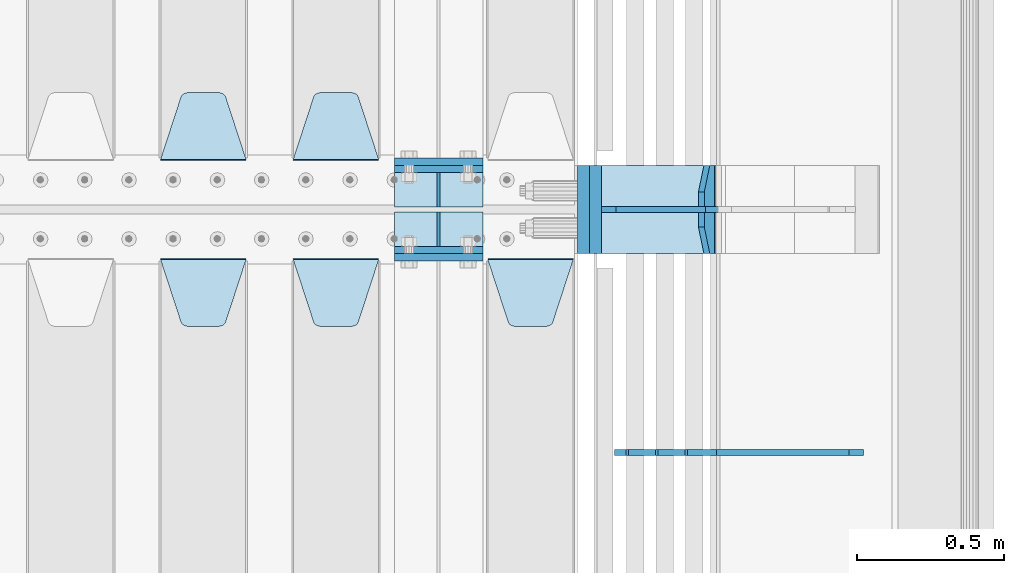
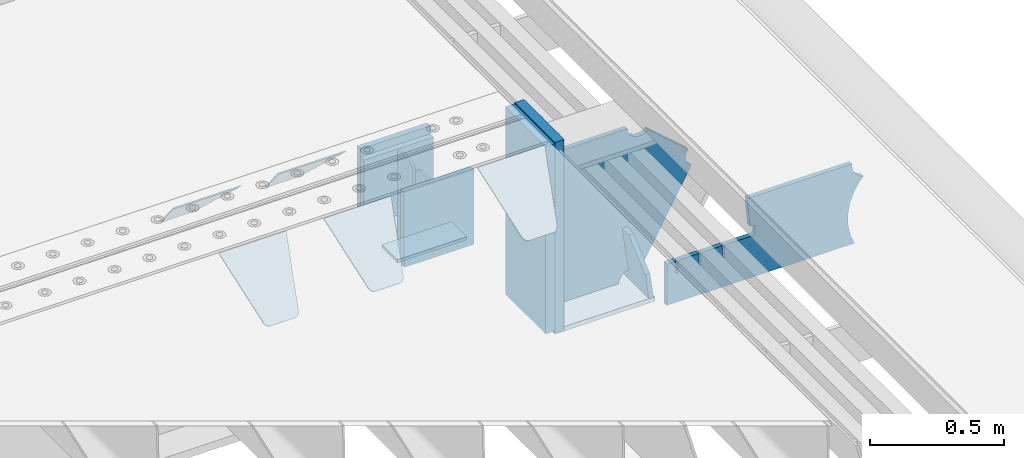
# One storey, part 247 of 270: 19 plates.
"""IFC2X3 building model written with IfcOpenShell, lengths in millimetres."""

from ifc_helpers import new_model, si_unit, frame, origin_with_axes, place, context, subcontext, project, spatial, faceted_brep, material, type_object, element, save


model = new_model("IFC2X3")

# Units and contexts
model_context = context("Model", 3, precision=1e-05, world=origin_with_axes())
body_context = subcontext(model_context, "Body", "Model", "MODEL_VIEW")
ifc_project = project(units=[si_unit("LENGTHUNIT", "METRE", prefix="MILLI"), si_unit("AREAUNIT", "SQUARE_METRE"), si_unit("VOLUMEUNIT", "CUBIC_METRE"), si_unit("MASSUNIT", "GRAM", prefix="KILO"), si_unit("TIMEUNIT", "SECOND"), si_unit("PLANEANGLEUNIT", "RADIAN"), si_unit("SOLIDANGLEUNIT", "STERADIAN"), si_unit("THERMODYNAMICTEMPERATUREUNIT", "DEGREE_CELSIUS"), si_unit("LUMINOUSINTENSITYUNIT", "LUMEN")], contexts=[model_context])

# Site, building, storey
site_placement = place(None, origin_with_axes())
site = spatial("IfcSite", under=ifc_project, at=site_placement, CompositionType="ELEMENT")
building_placement = place(site_placement, origin_with_axes())
building = spatial("IfcBuilding", under=site, at=building_placement, Name="Standard", CompositionType="ELEMENT")
storey_placement = place(building_placement, origin_with_axes())
storey = spatial("IfcBuildingStorey", under=building, at=storey_placement, Name="Undefined", CompositionType="ELEMENT", Elevation=0.0)

# Plates
ifc_material_1 = material(Name="STEEL/S355N")
plate_type_1 = type_object("IfcPlateType", PredefinedType="NOTDEFINED")
for number, where, z_axis, x_axis in (
    (1, (19768.0, -17862.5, -339.99999999999), (0.0, 0.0, 1.0), (1.0, 0.0, 0.0)),
    (2, (19768.0, -18137.5, -339.99999999999), (0.0, 0.0, 1.0), (1.0, 0.0, 0.0)),
):
    element("IfcPlate", number, at=place(storey_placement, frame(where, z_axis=z_axis, x_axis=x_axis)), inside=storey, type_object=plate_type_1, material=ifc_material_1, context=body_context, shape_type="Brep", body=[
        faceted_brep([(0.0, -12.5, 0.0), (0.0, -12.5, 305.0), (0.0, 12.5, 305.0), (0.0, 12.5, 0.0), (300.0, -12.5, 305.0), (300.0, 12.5, 305.0), (300.0, -12.5, 0.0), (300.0, 12.5, 0.0)], [[[0, 1, 2, 3]], [[1, 4, 5, 2]], [[4, 6, 7, 5]], [[6, 0, 3, 7]], [[5, 7, 3, 2]], [[6, 4, 1, 0]]]),
    ])
for number, where, z_axis, x_axis in (
    (3, (19768.0, -17837.5, -340.000000000044), (0.0, 0.0, 1.0), (1.0, 0.0, 0.0)),
    (4, (19768.0, -18162.5, -340.000000000044), (0.0, 0.0, 1.0), (1.0, 0.0, 0.0)),
):
    element("IfcPlate", number, at=place(storey_placement, frame(where, z_axis=z_axis, x_axis=x_axis)), inside=storey, type_object=plate_type_1, material=ifc_material_1, context=body_context, shape_type="Brep", body=[
        faceted_brep([(0.0, -12.5, 0.0), (9.27684595808387e-10, -12.5, 340.0), (9.27684595808387e-10, 12.5, 340.0), (0.0, 12.5, 0.0), (300.0, -12.5, 340.0), (300.0, 12.5, 340.0), (300.0, -12.5, 0.0), (300.0, 12.5, 0.0)], [[[0, 1, 2, 3]], [[1, 4, 5, 2]], [[4, 6, 7, 5]], [[6, 0, 3, 7]], [[5, 7, 3, 2]], [[6, 4, 1, 0]]]),
    ])
plate_type_2 = type_object("IfcPlateType", PredefinedType="NOTDEFINED")
for number, where, z_axis, x_axis in (
    (5, (19768.0, -17990.75, -342.99999999999), (0.0, 1.0, 0.0), (1.0, 0.0, 0.0)),
    (6, (19768.0, -18009.25, -342.99999999999), (0.0, -1.0, 0.0), (1.0, 0.0, 0.0)),
):
    element("IfcPlate", number, at=place(storey_placement, frame(where, z_axis=z_axis, x_axis=x_axis)), inside=storey, type_object=plate_type_2, material=ifc_material_1, context=body_context, shape_type="Brep", body=[
        faceted_brep([(0.0, -7.0, 0.0), (0.0, -7.0, 115.75), (0.0, 7.0, 115.75), (0.0, 7.0, 0.0), (300.0, -7.0, 115.75), (300.0, 7.0, 115.75), (300.0, -7.0, 0.0), (300.0, 7.0, 0.0)], [[[0, 1, 2, 3]], [[1, 4, 5, 2]], [[4, 6, 7, 5]], [[6, 0, 3, 7]], [[5, 7, 3, 2]], [[6, 4, 1, 0]]]),
    ])
plate_type_3 = type_object("IfcPlateType", PredefinedType="NOTDEFINED")
for number, where, z_axis, x_axis in (
    (7, (19918.0, -17990.75, -34.9999999999899), (0.0, 0.0, -1.0), (0.0, 1.0, 0.0)),
    (8, (19918.0, -18009.25, -34.9999999999899), (0.0, 0.0, -1.0), (0.0, -1.0, 0.0)),
):
    element("IfcPlate", number, at=place(storey_placement, frame(where, z_axis=z_axis, x_axis=x_axis)), inside=storey, type_object=plate_type_3, material=ifc_material_1, context=body_context, shape_type="Brep", body=[
        faceted_brep([(0.0, -5.0, 30.0), (0.0, -5.0, 301.0), (0.0, 5.0, 301.0), (0.0, 5.0, 30.0), (115.75, -5.0, 301.0), (115.75, 5.0, 301.0), (115.75, -5.0, 0.0), (115.75, 5.0, 0.0), (30.0, -5.0, 0.0), (30.0, 5.0, 0.0), (24.7905546699913, -5.0, 0.455767409633758), (24.7905546699913, 5.0, 0.455767409633758), (19.7393957002314, -5.0, 1.80922137642275), (19.7393957002314, 5.0, 1.80922137642275), (15.0, -5.0, 4.01923788646684), (15.0, 5.0, 4.01923788646684), (10.7163717094045, -5.0, 7.01866670643066), (10.7163717094045, 5.0, 7.01866670643066), (7.01866670642994, -5.0, 10.7163717094038), (7.01866670642994, 5.0, 10.7163717094038), (4.01923788646673, -5.0, 15.0), (4.01923788646673, 5.0, 15.0), (1.80922137642119, -5.0, 19.7393957002299), (1.80922137642119, 5.0, 19.7393957002299), (0.455767409632244, -5.0, 24.7905546699921), (0.455767409632244, 5.0, 24.7905546699921)], [[[0, 1, 2, 3]], [[1, 4, 5, 2]], [[4, 6, 7, 5]], [[6, 8, 9, 7]], [[8, 10, 11, 9]], [[10, 12, 13, 11]], [[12, 14, 15, 13]], [[14, 16, 17, 15]], [[16, 18, 19, 17]], [[18, 20, 21, 19]], [[20, 22, 23, 21]], [[22, 24, 25, 23]], [[24, 0, 3, 25]], [[5, 7, 9, 11, 13, 15, 17, 19, 21, 23, 25, 3, 2]], [[24, 22, 20, 18, 16, 14, 12, 10, 8, 6, 4, 1, 0]]]),
    ])
plate_type_4 = type_object("IfcPlateType", PredefinedType="NOTDEFINED")
plate_1_placement = place(storey_placement, frame((19715.0, -17831.767766953, -1.76776695296758), z_axis=(0.0, 0.707106781186547, -0.707106781186548), x_axis=(-1.0, 0.0, 0.0)))
element("IfcPlate", 9, at=plate_1_placement, inside=storey, type_object=plate_type_4, material=ifc_material_1, context=body_context, shape_type="Brep", body=[
    faceted_brep([(0.0, -2.5, 0.0), (69.345504679477, -2.5, 300.171731424831), (69.345504679477, 2.5, 300.171731424831), (0.0, 2.5, 0.0), (70.9274061199576, -2.5, 304.8974424154), (70.9274061199576, 2.5, 304.8974424154), (73.3818627772307, -2.49999999999818, 309.234538108527), (73.3818627772307, 2.50000000000182, 309.234538108527), (76.6187032999551, -2.5, 313.023683126103), (76.6187032999551, 2.5, 313.023683126103), (80.5190132704993, -2.5, 316.125672595372), (80.5190132704993, 2.50000000000182, 316.125672595372), (84.9395038596849, -2.49999999999818, 318.426546230476), (84.9395038596849, 2.5, 318.426546230476), (89.7177759439219, -2.49999999999818, 319.841774983275), (89.7177759439219, 2.50000000000182, 319.841774983275), (94.678286292652, -2.5, 320.319366455078), (94.678286292652, 2.5, 320.319366455078), (195.321713707348, -2.5, 320.319366455078), (195.321713707348, 2.5, 320.319366455078), (200.282224056078, -2.49999999999818, 319.841774983275), (200.282224056078, 2.50000000000182, 319.841774983275), (205.060496140315, -2.5, 318.426546230476), (205.060496140315, 2.5, 318.426546230476), (209.480986729501, -2.5, 316.12567259537), (209.480986729501, 2.50000000000182, 316.12567259537), (213.381296700045, -2.5, 313.023683126103), (213.381296700045, 2.5, 313.023683126103), (216.618137222769, -2.49999999999818, 309.234538108525), (216.618137222769, 2.50000000000182, 309.234538108527), (219.072593880042, -2.49999999999818, 304.897442415398), (219.072593880042, 2.50000000000182, 304.897442415397), (220.654495320523, -2.5, 300.171731424831), (220.654495320523, 2.5, 300.171731424831), (290.0, -2.49999999999818, 0.0), (290.0, 2.5, 0.0)], [[[0, 1, 2, 3]], [[1, 4, 5, 2]], [[4, 6, 7, 5]], [[6, 8, 9, 7]], [[8, 10, 11, 9]], [[10, 12, 13, 11]], [[12, 14, 15, 13]], [[14, 16, 17, 15]], [[16, 18, 19, 17]], [[18, 20, 21, 19]], [[20, 22, 23, 21]], [[22, 24, 25, 23]], [[24, 26, 27, 25]], [[26, 28, 29, 27]], [[28, 30, 31, 29]], [[30, 32, 33, 31]], [[32, 34, 35, 33]], [[34, 0, 3, 35]], [[5, 7, 9, 11, 13, 15, 17, 19, 21, 23, 25, 27, 29, 31, 33, 35, 3, 2]], [[34, 32, 30, 28, 26, 24, 22, 20, 18, 16, 14, 12, 10, 8, 6, 4, 1, 0]]]),
])
plate_2_placement = place(storey_placement, frame((19265.0, -17831.767766953, -1.76776695296758), z_axis=(0.0, 0.707106781186547, -0.707106781186548), x_axis=(-1.0, 0.0, 0.0)))
element("IfcPlate", 10, at=plate_2_placement, inside=storey, type_object=plate_type_4, material=ifc_material_1, context=body_context, shape_type="Brep", body=[
    faceted_brep([(0.0, -2.5, 0.0), (69.345504679477, -2.5, 300.171731424831), (69.345504679477, 2.5, 300.171731424831), (0.0, 2.5, 0.0), (70.9274061199576, -2.5, 304.8974424154), (70.9274061199576, 2.5, 304.8974424154), (73.3818627772307, -2.49999999999818, 309.234538108527), (73.3818627772307, 2.50000000000182, 309.234538108527), (76.6187032999551, -2.5, 313.023683126103), (76.6187032999551, 2.5, 313.023683126103), (80.5190132704993, -2.5, 316.125672595372), (80.5190132704993, 2.50000000000182, 316.125672595372), (84.9395038596849, -2.49999999999818, 318.426546230476), (84.9395038596849, 2.5, 318.426546230476), (89.7177759439219, -2.49999999999818, 319.841774983275), (89.7177759439219, 2.50000000000182, 319.841774983275), (94.678286292652, -2.5, 320.319366455078), (94.678286292652, 2.5, 320.319366455078), (195.321713707348, -2.5, 320.319366455078), (195.321713707348, 2.5, 320.319366455078), (200.282224056078, -2.49999999999818, 319.841774983275), (200.282224056078, 2.50000000000182, 319.841774983275), (205.060496140315, -2.5, 318.426546230476), (205.060496140315, 2.5, 318.426546230476), (209.480986729501, -2.5, 316.12567259537), (209.480986729501, 2.50000000000182, 316.12567259537), (213.381296700045, -2.5, 313.023683126103), (213.381296700045, 2.5, 313.023683126103), (216.618137222769, -2.49999999999818, 309.234538108525), (216.618137222769, 2.50000000000182, 309.234538108527), (219.072593880042, -2.49999999999818, 304.897442415398), (219.072593880042, 2.50000000000182, 304.897442415397), (220.654495320523, -2.5, 300.171731424831), (220.654495320523, 2.5, 300.171731424831), (290.0, -2.49999999999818, 0.0), (290.0, 2.5, 0.0)], [[[0, 1, 2, 3]], [[1, 4, 5, 2]], [[4, 6, 7, 5]], [[6, 8, 9, 7]], [[8, 10, 11, 9]], [[10, 12, 13, 11]], [[12, 14, 15, 13]], [[14, 16, 17, 15]], [[16, 18, 19, 17]], [[18, 20, 21, 19]], [[20, 22, 23, 21]], [[22, 24, 25, 23]], [[24, 26, 27, 25]], [[26, 28, 29, 27]], [[28, 30, 31, 29]], [[30, 32, 33, 31]], [[32, 34, 35, 33]], [[34, 0, 3, 35]], [[5, 7, 9, 11, 13, 15, 17, 19, 21, 23, 25, 27, 29, 31, 33, 35, 3, 2]], [[34, 32, 30, 28, 26, 24, 22, 20, 18, 16, 14, 12, 10, 8, 6, 4, 1, 0]]]),
])
plate_3_placement = place(storey_placement, frame((20085.0, -18168.232233044, -1.76776695296576), z_axis=(0.0, -0.707106781186548, -0.707106781186547), x_axis=(1.0, 0.0, 0.0)))
element("IfcPlate", 11, at=plate_3_placement, inside=storey, type_object=plate_type_4, material=ifc_material_1, context=body_context, shape_type="Brep", body=[
    faceted_brep([(0.0, -2.5, 0.0), (69.345504679477, -2.5, 300.171731424831), (69.345504679477, 2.5, 300.171731424831), (0.0, 2.5, 0.0), (70.9274061199576, -2.5, 304.8974424154), (70.9274061199576, 2.5, 304.8974424154), (73.3818627772307, -2.49999999999818, 309.234538108527), (73.3818627772307, 2.50000000000182, 309.234538108527), (76.6187032999551, -2.5, 313.023683126103), (76.6187032999551, 2.5, 313.023683126103), (80.5190132704993, -2.5, 316.125672595372), (80.5190132704993, 2.50000000000182, 316.125672595372), (84.9395038596849, -2.49999999999818, 318.426546230476), (84.9395038596849, 2.5, 318.426546230476), (89.7177759439219, -2.49999999999818, 319.841774983275), (89.7177759439219, 2.50000000000182, 319.841774983275), (94.678286292652, -2.5, 320.319366455078), (94.678286292652, 2.5, 320.319366455078), (195.321713707348, -2.5, 320.319366455078), (195.321713707348, 2.5, 320.319366455078), (200.282224056078, -2.49999999999818, 319.841774983275), (200.282224056078, 2.50000000000182, 319.841774983275), (205.060496140315, -2.5, 318.426546230476), (205.060496140315, 2.5, 318.426546230476), (209.480986729501, -2.5, 316.12567259537), (209.480986729501, 2.50000000000182, 316.12567259537), (213.381296700045, -2.5, 313.023683126103), (213.381296700045, 2.5, 313.023683126103), (216.618137222769, -2.49999999999818, 309.234538108525), (216.618137222769, 2.50000000000182, 309.234538108527), (219.072593880042, -2.49999999999818, 304.897442415398), (219.072593880042, 2.50000000000182, 304.897442415397), (220.654495320523, -2.5, 300.171731424831), (220.654495320523, 2.5, 300.171731424831), (290.0, -2.49999999999818, 0.0), (290.0, 2.5, 0.0)], [[[0, 1, 2, 3]], [[1, 4, 5, 2]], [[4, 6, 7, 5]], [[6, 8, 9, 7]], [[8, 10, 11, 9]], [[10, 12, 13, 11]], [[12, 14, 15, 13]], [[14, 16, 17, 15]], [[16, 18, 19, 17]], [[18, 20, 21, 19]], [[20, 22, 23, 21]], [[22, 24, 25, 23]], [[24, 26, 27, 25]], [[26, 28, 29, 27]], [[28, 30, 31, 29]], [[30, 32, 33, 31]], [[32, 34, 35, 33]], [[34, 0, 3, 35]], [[5, 7, 9, 11, 13, 15, 17, 19, 21, 23, 25, 27, 29, 31, 33, 35, 3, 2]], [[34, 32, 30, 28, 26, 24, 22, 20, 18, 16, 14, 12, 10, 8, 6, 4, 1, 0]]]),
])
plate_4_placement = place(storey_placement, frame((19425.0, -18168.232233044, -1.76776695296576), z_axis=(0.0, -0.707106781186548, -0.707106781186547), x_axis=(1.0, 0.0, 0.0)))
element("IfcPlate", 12, at=plate_4_placement, inside=storey, type_object=plate_type_4, material=ifc_material_1, context=body_context, shape_type="Brep", body=[
    faceted_brep([(0.0, -2.5, 0.0), (69.345504679477, -2.5, 300.171731424831), (69.345504679477, 2.5, 300.171731424831), (0.0, 2.5, 0.0), (70.9274061199576, -2.5, 304.8974424154), (70.9274061199576, 2.5, 304.8974424154), (73.3818627772307, -2.49999999999818, 309.234538108527), (73.3818627772307, 2.50000000000182, 309.234538108527), (76.6187032999551, -2.5, 313.023683126103), (76.6187032999551, 2.5, 313.023683126103), (80.5190132704993, -2.5, 316.125672595372), (80.5190132704993, 2.50000000000182, 316.125672595372), (84.9395038596849, -2.49999999999818, 318.426546230476), (84.9395038596849, 2.5, 318.426546230476), (89.7177759439219, -2.49999999999818, 319.841774983275), (89.7177759439219, 2.50000000000182, 319.841774983275), (94.678286292652, -2.5, 320.319366455078), (94.678286292652, 2.5, 320.319366455078), (195.321713707348, -2.5, 320.319366455078), (195.321713707348, 2.5, 320.319366455078), (200.282224056078, -2.49999999999818, 319.841774983275), (200.282224056078, 2.50000000000182, 319.841774983275), (205.060496140315, -2.5, 318.426546230476), (205.060496140315, 2.5, 318.426546230476), (209.480986729501, -2.5, 316.12567259537), (209.480986729501, 2.50000000000182, 316.12567259537), (213.381296700045, -2.5, 313.023683126103), (213.381296700045, 2.5, 313.023683126103), (216.618137222769, -2.49999999999818, 309.234538108525), (216.618137222769, 2.50000000000182, 309.234538108527), (219.072593880042, -2.49999999999818, 304.897442415398), (219.072593880042, 2.50000000000182, 304.897442415397), (220.654495320523, -2.5, 300.171731424831), (220.654495320523, 2.5, 300.171731424831), (290.0, -2.49999999999818, 0.0), (290.0, 2.5, 0.0)], [[[0, 1, 2, 3]], [[1, 4, 5, 2]], [[4, 6, 7, 5]], [[6, 8, 9, 7]], [[8, 10, 11, 9]], [[10, 12, 13, 11]], [[12, 14, 15, 13]], [[14, 16, 17, 15]], [[16, 18, 19, 17]], [[18, 20, 21, 19]], [[20, 22, 23, 21]], [[22, 24, 25, 23]], [[24, 26, 27, 25]], [[26, 28, 29, 27]], [[28, 30, 31, 29]], [[30, 32, 33, 31]], [[32, 34, 35, 33]], [[34, 0, 3, 35]], [[5, 7, 9, 11, 13, 15, 17, 19, 21, 23, 25, 27, 29, 31, 33, 35, 3, 2]], [[34, 32, 30, 28, 26, 24, 22, 20, 18, 16, 14, 12, 10, 8, 6, 4, 1, 0]]]),
])
plate_5_placement = place(storey_placement, frame((18975.0, -18168.232233044, -1.76776695296576), z_axis=(0.0, -0.707106781186548, -0.707106781186547), x_axis=(1.0, 0.0, 0.0)))
element("IfcPlate", 13, at=plate_5_placement, inside=storey, type_object=plate_type_4, material=ifc_material_1, context=body_context, shape_type="Brep", body=[
    faceted_brep([(0.0, -2.5, 0.0), (69.345504679477, -2.5, 300.171731424831), (69.345504679477, 2.5, 300.171731424831), (0.0, 2.5, 0.0), (70.9274061199576, -2.5, 304.8974424154), (70.9274061199576, 2.5, 304.8974424154), (73.3818627772307, -2.49999999999818, 309.234538108527), (73.3818627772307, 2.50000000000182, 309.234538108527), (76.6187032999551, -2.5, 313.023683126103), (76.6187032999551, 2.5, 313.023683126103), (80.5190132704993, -2.5, 316.125672595372), (80.5190132704993, 2.50000000000182, 316.125672595372), (84.9395038596849, -2.49999999999818, 318.426546230476), (84.9395038596849, 2.5, 318.426546230476), (89.7177759439219, -2.49999999999818, 319.841774983275), (89.7177759439219, 2.50000000000182, 319.841774983275), (94.678286292652, -2.5, 320.319366455078), (94.678286292652, 2.5, 320.319366455078), (195.321713707348, -2.5, 320.319366455078), (195.321713707348, 2.5, 320.319366455078), (200.282224056078, -2.49999999999818, 319.841774983275), (200.282224056078, 2.50000000000182, 319.841774983275), (205.060496140315, -2.5, 318.426546230476), (205.060496140315, 2.5, 318.426546230476), (209.480986729501, -2.5, 316.12567259537), (209.480986729501, 2.50000000000182, 316.12567259537), (213.381296700045, -2.5, 313.023683126103), (213.381296700045, 2.5, 313.023683126103), (216.618137222769, -2.49999999999818, 309.234538108525), (216.618137222769, 2.50000000000182, 309.234538108527), (219.072593880042, -2.49999999999818, 304.897442415398), (219.072593880042, 2.50000000000182, 304.897442415397), (220.654495320523, -2.5, 300.171731424831), (220.654495320523, 2.5, 300.171731424831), (290.0, -2.49999999999818, 0.0), (290.0, 2.5, 0.0)], [[[0, 1, 2, 3]], [[1, 4, 5, 2]], [[4, 6, 7, 5]], [[6, 8, 9, 7]], [[8, 10, 11, 9]], [[10, 12, 13, 11]], [[12, 14, 15, 13]], [[14, 16, 17, 15]], [[16, 18, 19, 17]], [[18, 20, 21, 19]], [[20, 22, 23, 21]], [[22, 24, 25, 23]], [[24, 26, 27, 25]], [[26, 28, 29, 27]], [[28, 30, 31, 29]], [[30, 32, 33, 31]], [[32, 34, 35, 33]], [[34, 0, 3, 35]], [[5, 7, 9, 11, 13, 15, 17, 19, 21, 23, 25, 27, 29, 31, 33, 35, 3, 2]], [[34, 32, 30, 28, 26, 24, 22, 20, 18, 16, 14, 12, 10, 8, 6, 4, 1, 0]]]),
])
plate_type_5 = type_object("IfcPlateType", PredefinedType="NOTDEFINED")
plate_6_placement = place(storey_placement, frame((20844.0775331946, -17849.9999999983, -871.412303810021), z_axis=(0.0, -1.0, 0.0), x_axis=(-0.137902988002447, 0.0, 0.990445741017648)))
element("IfcPlate", 14, at=plate_6_placement, inside=storey, type_object=plate_type_5, material=ifc_material_1, context=body_context, shape_type="Brep", body=[
    faceted_brep([(0.0, -10.0, 0.0), (-1.98724592337385e-10, -10.0000000000036, 300.0), (-1.98724592337385e-10, 10.0, 300.0), (0.0, 10.0, 0.0), (115.0, -10.0000000000036, 300.0), (115.0, 9.99999999999272, 300.0), (250.0, -10.0, 210.0), (250.0, 9.99999999999636, 210.0), (250.0, -10.0, 90.0), (250.0, 9.99999999999636, 90.0), (115.0, -10.0000000000036, -1.09139364212751e-10), (115.0, 9.99999999999272, -1.09139364212751e-10)], [[[0, 1, 2, 3]], [[1, 4, 5, 2]], [[4, 6, 7, 5]], [[6, 8, 9, 7]], [[8, 10, 11, 9]], [[10, 0, 3, 11]], [[5, 7, 9, 11, 3, 2]], [[10, 8, 6, 4, 1, 0]]]),
])
plate_type_6 = type_object("IfcPlateType", PredefinedType="NOTDEFINED")
plate_7_placement = place(storey_placement, frame((20872.9988298913, -17999.9999999999, -179.999999999866), z_axis=(0.0, 0.0, -1.0), x_axis=(-1.0, 0.0, 0.0)))
element("IfcPlate", 15, at=plate_7_placement, inside=storey, type_object=plate_type_6, material=ifc_material_1, context=body_context, shape_type="Brep", body=[
    faceted_brep([(46.0258547361445, 10.0, 641.078828352486), (73.3015011074785, 10.0000000000073, 445.179898435767), (73.3015011074785, -9.99999999998909, 445.179898435767), (46.0258547361445, -10.0, 641.078828352486), (53.4925862871278, 10.0000000000073, 442.421838675718), (53.4925862871278, -9.99999999998909, 442.421838675718), (25.7820501123933, 10.0, 641.444230671287), (25.7820501123933, -10.0, 641.444230671287), (54.6652503111618, 10.0, 642.447174185377), (54.6652503111618, -10.0, 642.447174185377), (68.6036632070354, -10.0, 649.549150281387), (68.6036632070354, 10.0, 649.549150281387), (79.6652503111618, -10.0, 660.610737385511), (79.6652503111618, 10.0, 660.610737385511), (86.7672264071698, -10.0, 674.549150281387), (86.7672264071698, 10.0, 674.549150281387), (89.2144005924129, -10.0, 690.0), (89.2144005924129, 10.0, 690.0), (353.0, -10.0, 690.0), (353.0, 10.0, 690.0), (355.447174185243, -10.0, 674.549150281253), (355.447174185243, 10.0, 674.549150281253), (362.549150281251, -10.0, 660.610737385376), (362.549150281251, 10.0, 660.610737385376), (373.610737385377, -10.0, 649.549150281253), (373.610737385377, 10.0, 649.549150281253), (387.549150281251, -10.0, 642.447174185242), (387.549150281251, 10.0, 642.447174185242), (403.0, -10.0, 640.0), (403.0, 10.0, 640.0), (403.0, -10.0, 50.0), (403.0, 10.0, 50.0), (387.549150281251, -10.0, 47.5528258147577), (387.549150281251, 10.0, 47.5528258147577), (373.610737385377, -10.0, 40.4508497187474), (373.610737385377, 10.0, 40.4508497187474), (362.549150281251, -10.0, 29.3892626146236), (362.549150281251, 10.0, 29.3892626146236), (355.447174185243, -10.0, 15.4508497187474), (355.447174185243, 10.0, 15.4508497187474), (353.0, -10.0, 0.0), (353.0, 10.0, 0.0), (50.0, -10.0, 0.0), (50.0, 10.0, 0.0), (47.0349915316328, -10.0, 16.9620037619133), (47.0349915316328, 10.0, 16.9620037619133), (38.4916171352343, -10.0, 31.9123081320451), (38.4916171352343, 10.0, 31.9123081320451), (25.3831239081519, -10.0, 43.0778019479116), (25.3831239081519, 10.0, 43.0778019479116), (9.26418358741648, -10.0, 49.1342538608113), (9.26418358741648, 10.0, 49.1342538608113), (-7.95349204488593, -10.0, 49.363366622344), (-7.95349204488593, 10.0, 49.363366622344), (-24.2278808265401, -10.0, 43.7379673813837), (-24.2278808265401, 10.0, 43.7379673813837), (-37.6288347353438, -10.0, 32.9252303934259), (-37.6288347353438, 10.0, 32.9252303934259), (-210.371165264656, -10.0, 184.074769606574), (-210.371165264656, 10.0, 184.074769606574), (-202.382363280569, -10.0, 196.529747922069), (-202.382363280569, 10.0, 196.529747922069), (-198.388707244045, -10.0, 210.777489969227), (-198.388707244045, 10.0, 210.777489969227), (-198.739957464426, -10.0, 225.570193077959), (-198.739957464426, 10.0, 225.570193077959), (-203.40535180681, -10.0, 239.612327446012), (-203.40535180681, 10.0, 239.612327446012), (-211.976299808361, -10.0, 251.674097313455), (-211.976299808361, 10.0, 251.674097313455), (-223.702166612962, -10.0, 260.699145216992), (-223.702166612962, 10.0, 260.699145216992), (-9.29783338703783, -10.0, 646.300854783008), (-9.29783338703783, 10.0, 646.300854783008), (6.98069453597782, -10.0, 640.647282345602), (6.98069453597782, 10.0, 640.647282345602), (24.2117663163663, -10.0, 640.855891896051), (24.2117663163663, 10.0, 640.855891896051)], [[[0, 1, 2, 3]], [[4, 5, 2, 1]], [[6, 7, 5, 4]], [[8, 9, 10, 11]], [[11, 10, 12, 13]], [[13, 12, 14, 15]], [[15, 14, 16, 17]], [[18, 19, 17, 16]], [[18, 20, 21, 19]], [[20, 22, 23, 21]], [[22, 24, 25, 23]], [[24, 26, 27, 25]], [[26, 28, 29, 27]], [[28, 30, 31, 29]], [[30, 32, 33, 31]], [[32, 34, 35, 33]], [[34, 36, 37, 35]], [[36, 38, 39, 37]], [[38, 40, 41, 39]], [[40, 42, 43, 41]], [[42, 44, 45, 43]], [[44, 46, 47, 45]], [[46, 48, 49, 47]], [[48, 50, 51, 49]], [[50, 52, 53, 51]], [[52, 54, 55, 53]], [[54, 56, 57, 55]], [[56, 58, 59, 57]], [[58, 60, 61, 59]], [[60, 62, 63, 61]], [[62, 64, 65, 63]], [[64, 66, 67, 65]], [[66, 68, 69, 67]], [[68, 70, 71, 69]], [[70, 72, 73, 71]], [[72, 74, 75, 73]], [[74, 76, 77, 75]], [[1, 0, 8, 11, 13, 15, 17, 19, 21, 23, 25, 27, 29, 31, 33, 35, 37, 39, 41, 43, 45, 47, 49, 51, 53, 55, 57, 59, 61, 63, 65, 67, 69, 71, 73, 75, 77, 6, 4]], [[9, 8, 0, 3]], [[76, 74, 72, 70, 68, 66, 64, 62, 60, 58, 56, 54, 52, 50, 48, 46, 44, 42, 40, 38, 36, 34, 32, 30, 28, 26, 24, 22, 20, 18, 16, 14, 12, 10, 9, 3, 2, 5, 7]], [[77, 76, 7, 6]]]),
])
plate_type_7 = type_object("IfcPlateType", PredefinedType="NOTDEFINED")
plate_8_placement = place(storey_placement, frame((20469.9988298913, -17849.9999999999, -879.999999999866), z_axis=(0.0, -1.0, 0.0), x_axis=(1.0, 0.0, 0.0)))
element("IfcPlate", 16, at=plate_8_placement, inside=storey, type_object=plate_type_7, material=ifc_material_1, context=body_context, shape_type="Brep", body=[
    faceted_brep([(0.0, -10.0, 0.0), (-1.98724592337385e-10, -10.0000000000036, 300.0), (-1.98724592337385e-10, 10.0, 300.0), (0.0, 10.0, 0.0), (389.0, -10.0, 300.0), (389.0, 10.0, 300.0), (389.0, -10.0, 0.0), (389.0, 10.0, 0.0)], [[[0, 1, 2, 3]], [[1, 4, 5, 2]], [[4, 6, 7, 5]], [[6, 0, 3, 7]], [[5, 7, 3, 2]], [[6, 4, 1, 0]]]),
])
ifc_material_2 = material()
plate_type_8 = type_object("IfcPlateType", PredefinedType="NOTDEFINED")
plate_9_placement = place(storey_placement, frame((20410.0, -17850.0, -875.0), z_axis=(0.0, 0.0, 1.0), x_axis=(0.0, -1.0, 0.0)))
element("IfcPlate", 17, at=plate_9_placement, inside=storey, type_object=plate_type_8, material=ifc_material_2, context=body_context, shape_type="Brep", body=[
    faceted_brep([(0.0, -20.0, 0.0), (0.0, -20.0, 850.0), (0.0, 20.0, 850.0), (0.0, 20.0, 0.0), (300.0, -20.0, 850.0), (300.0, 20.0, 850.0), (300.0, -20.0, -1.81898940354586e-12), (300.0, 20.0, -1.81898940354586e-12)], [[[0, 1, 2, 3]], [[1, 4, 5, 2]], [[4, 6, 7, 5]], [[6, 0, 3, 7]], [[5, 7, 3, 2]], [[6, 4, 1, 0]]]),
])
plate_10_placement = place(storey_placement, frame((20449.9988298906, -17850.0, -889.999999999995), z_axis=(0.0, 0.0, 1.0), x_axis=(0.0, -1.0, 0.0)))
element("IfcPlate", 18, at=plate_10_placement, inside=storey, type_object=plate_type_8, material=ifc_material_2, context=body_context, shape_type="Brep", body=[
    faceted_brep([(0.0, -20.0, 0.0), (0.0, -20.0, 870.0), (0.0, 20.0, 870.0), (0.0, 20.0, 0.0), (300.0, -20.0, 870.0), (300.0, 20.0, 870.0), (300.0, -20.0, -1.81898940354586e-12), (300.0, 20.0, -1.81898940354586e-12)], [[[0, 1, 2, 3]], [[1, 4, 5, 2]], [[4, 6, 7, 5]], [[6, 0, 3, 7]], [[5, 7, 3, 2]], [[6, 4, 1, 0]]]),
])
plate_type_9 = type_object("IfcPlateType", PredefinedType="NOTDEFINED")
plate_11_placement = place(storey_placement, frame((21355.9182339676, -18825.0007171631, -374.002067436516), z_axis=(0.0, 0.0, 1.0), x_axis=(-1.0, 0.0, 0.0)))
element("IfcPlate", 19, at=plate_11_placement, inside=storey, type_object=plate_type_9, material=ifc_material_1, context=body_context, shape_type="Brep", body=[
    faceted_brep([(801.919404066546, -10.0, 188.0), (801.919404066546, 10.0, 188.0), (801.919404066546, 10.0, 132.002067436952), (801.919404066546, -10.0, 132.002067436952), (793.919404066546, 10.0, 132.002067436952), (793.919404066546, -10.0, 132.002067436952), (793.919404066546, 10.0, 180.002067436952), (793.919404066546, -10.0, 180.002067436952), (793.527856196906, 10.0, 182.474203391951), (793.527856196906, -10.0, 182.474203391951), (792.391540021545, 10.0, 184.704349455291), (792.391540021545, -10.0, 184.704349455291), (790.621686084887, 10.0, 186.474203391951), (790.621686084887, -10.0, 186.474203391951), (788.391540021545, 10.0, 187.610519567313), (788.391540021545, -10.0, 187.610519567313), (785.919404066546, -10.0, 188.002067436952), (785.919404066546, 10.0, 188.0), (841.0, -10.0, 188.0), (841.0, -10.0, 0.0), (841.0, 10.0, 0.0), (841.0, 10.0, 188.0), (33.3619566735979, -10.0, 0.0), (33.3619566735979, 10.0, 0.0), (36.2350612208174, -10.0, 4.68848050267013), (36.2350612208174, 10.0, 4.68848050267013), (51.4877592159428, -10.0, 41.5117508652784), (51.4877592159428, 10.0, 41.5117508652784), (60.792242588137, -10.0, 80.2677133162964), (60.792242588137, 10.0, 80.2677133162964), (63.9194040769726, -10.0, 120.002067436515), (63.9194040769726, 10.0, 120.002067436515), (60.792242588137, -10.0, 159.736421556734), (60.792242588137, 10.0, 159.736421556734), (51.4877592159428, -10.0, 198.492384007752), (51.4877592159428, 10.0, 198.492384007752), (36.2350612208174, -10.0, 235.31565437036), (36.2350612208174, 10.0, 235.31565437036), (15.4097206482074, -10.0, 269.299521518803), (15.4097206482074, 10.0, 269.299521518803), (-3.35474438098754, -10.0, 291.269887256574), (-3.35474438098754, 10.0, 291.269887256574), (-2.36881039375294, -10.0, 291.426043859339), (-2.36881039375294, 10.0, 291.426043859339), (17.1449676604716, -10.0, 301.368810393754), (17.1449676604716, 10.0, 301.368810393754), (32.6311896062471, -10.0, 316.855032339527), (32.6311896062471, 10.0, 316.855032339527), (42.573956140659, -10.0, 336.368810393754), (42.573956140659, 10.0, 336.368810393754), (46.0, -10.0, 358.0), (46.0, 10.0, 358.0), (45.0495205499174, -10.0, 364.001091067617), (45.0495205499174, 10.0, 364.001091067617), (495.040008544922, -10.0, 364.010009765625), (495.040008544922, 10.0, 364.010009765625), (483.600036621094, -10.0, 233.759994506836), (483.600036621094, 10.0, 233.759994506836), (472.0, -10.0, 233.759994506836), (472.0, 10.0, 233.759994506836), (468.909830056251, -10.0, 233.270559669787), (468.909830056251, 10.0, 233.270559669787), (466.122147477075, -10.0, 231.850164450585), (466.122147477075, 10.0, 231.850164450585), (463.909830056251, -10.0, 229.637847029761), (463.909830056251, 10.0, 229.637847029761), (462.489434837047, -10.0, 226.850164450585), (462.489434837047, 10.0, 226.850164450585), (462.0, -10.0, 223.759994506836), (462.0, 10.0, 223.759994506836), (462.0, -10.0, 198.0), (462.0, 10.0, 198.0), (462.489434837047, -10.0, 194.909830056251), (462.489434837047, 10.0, 194.909830056251), (463.909830056251, -10.0, 192.122147477075), (463.909830056251, 10.0, 192.122147477075), (466.122147477075, -10.0, 189.909830056251), (466.122147477075, 10.0, 189.909830056251), (468.909830056251, -10.0, 188.489434837048), (468.909830056251, 10.0, 188.489434837048), (472.0, -10.0, 188.0), (472.0, 10.0, 188.0), (585.919404066546, -10.0, 188.002067436952), (585.919404066546, 10.0, 188.0), (588.391540021545, -10.0, 187.610519567313), (588.391540021545, 10.0, 187.610519567313), (590.621686084887, -10.0, 186.474203391951), (590.621686084887, 10.0, 186.474203391951), (592.391540021545, -10.0, 184.704349455291), (592.391540021545, 10.0, 184.704349455291), (593.527856196906, -10.0, 182.474203391951), (593.527856196906, 10.0, 182.474203391951), (593.919404066546, -10.0, 180.002067436952), (593.919404066546, 10.0, 180.002067436952), (593.919404066546, -10.0000000000036, 132.002067436952), (593.919404066546, 10.0, 132.002067436952), (601.919404066546, -10.0000000000036, 132.002067436952), (601.919404066546, 10.0, 132.002067436952), (601.919404066546, -10.0, 188.0), (601.919404066546, 10.0, 188.0), (685.919404066546, -10.0, 188.002067436952), (685.919404066546, 10.0, 188.0), (688.391540021545, -10.0, 187.610519567313), (688.391540021545, 10.0, 187.610519567313), (690.621686084887, -10.0, 186.474203391951), (690.621686084887, 10.0, 186.474203391951), (692.391540021545, -10.0, 184.704349455291), (692.391540021545, 10.0, 184.704349455291), (693.527856196906, -10.0, 182.474203391951), (693.527856196906, 10.0, 182.474203391951), (693.919404066546, -10.0, 180.002067436952), (693.919404066546, 10.0, 180.002067436952), (693.919404066546, -10.0, 132.002067436952), (693.919404066546, 10.0, 132.002067436952), (701.919404066546, -10.0, 132.002067436952), (701.919404066546, 10.0, 132.002067436952), (701.919404066546, -10.0, 188.0), (701.919404066546, 10.0, 188.0)], [[[0, 1, 2, 3]], [[3, 2, 4, 5]], [[5, 4, 6, 7]], [[7, 6, 8, 9]], [[9, 8, 10, 11]], [[11, 10, 12, 13]], [[13, 12, 14, 15]], [[16, 15, 14, 17]], [[18, 19, 20, 21]], [[20, 19, 22, 23]], [[22, 24, 25, 23]], [[26, 27, 25, 24]], [[28, 29, 27, 26]], [[30, 31, 29, 28]], [[32, 33, 31, 30]], [[34, 35, 33, 32]], [[36, 37, 35, 34]], [[38, 39, 37, 36]], [[39, 38, 40, 41]], [[40, 42, 43, 41]], [[44, 45, 43, 42]], [[46, 47, 45, 44]], [[48, 49, 47, 46]], [[50, 51, 49, 48]], [[52, 53, 51, 50]], [[54, 55, 53, 52]], [[54, 56, 57, 55]], [[56, 58, 59, 57]], [[58, 60, 61, 59]], [[60, 62, 63, 61]], [[62, 64, 65, 63]], [[64, 66, 67, 65]], [[66, 68, 69, 67]], [[68, 70, 71, 69]], [[70, 72, 73, 71]], [[72, 74, 75, 73]], [[74, 76, 77, 75]], [[76, 78, 79, 77]], [[78, 80, 81, 79]], [[81, 80, 82, 83]], [[82, 84, 85, 83]], [[86, 87, 85, 84]], [[88, 89, 87, 86]], [[90, 91, 89, 88]], [[92, 93, 91, 90]], [[94, 95, 93, 92]], [[96, 97, 95, 94]], [[98, 99, 97, 96]], [[99, 98, 100, 101]], [[100, 102, 103, 101]], [[104, 105, 103, 102]], [[106, 107, 105, 104]], [[108, 109, 107, 106]], [[110, 111, 109, 108]], [[112, 113, 111, 110]], [[114, 115, 113, 112]], [[116, 117, 115, 114]], [[117, 116, 16, 17]], [[12, 10, 8, 6, 4, 2, 1, 21, 20, 23, 25, 27, 29, 31, 33, 35, 37, 39, 41, 43, 45, 47, 49, 51, 53, 55, 57, 59, 61, 63, 65, 67, 69, 71, 73, 75, 77, 79, 81, 83, 85, 87, 89, 91, 93, 95, 97, 99, 101, 103, 105, 107, 109, 111, 113, 115, 117, 17, 14]], [[18, 21, 1, 0]], [[116, 114, 112, 110, 108, 106, 104, 102, 100, 98, 96, 94, 92, 90, 88, 86, 84, 82, 80, 78, 76, 74, 72, 70, 68, 66, 64, 62, 60, 58, 56, 54, 52, 50, 48, 46, 44, 42, 40, 38, 36, 34, 32, 30, 28, 26, 24, 22, 19, 18, 0, 3, 5, 7, 9, 11, 13, 15, 16]]]),
])

save(model, "model.ifc")
